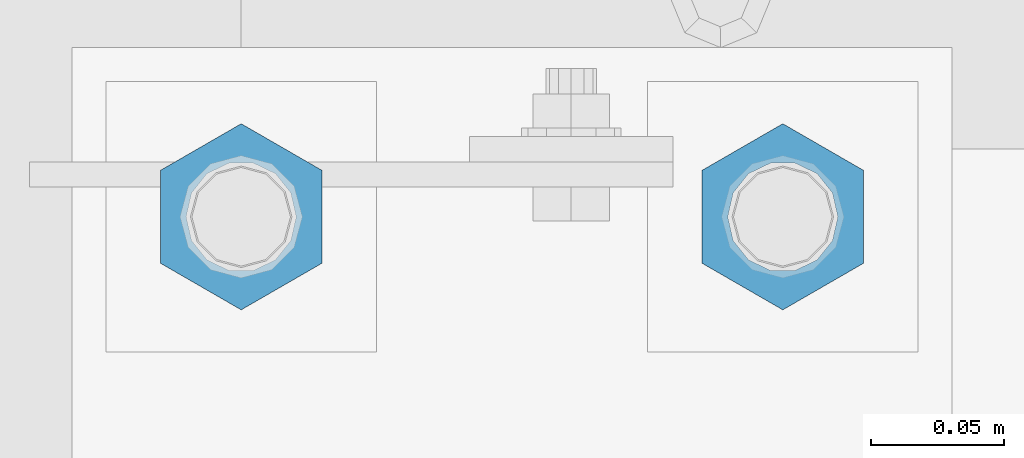
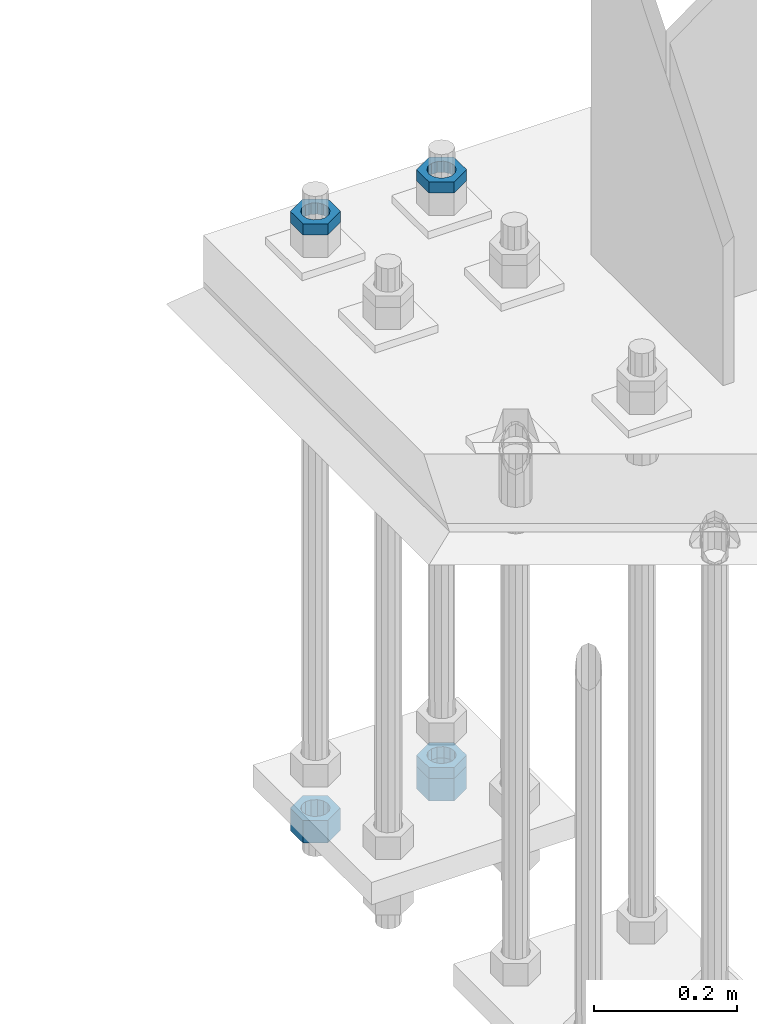
# One storey, part 2932 of 3843: 5 beams, 1 element without a shape of its own.
"""IFC2X3 building model written with IfcOpenShell, lengths in millimetres."""

import ifcopenshell
import ifcopenshell.guid

model = None  # the IFC model being written
_history = None  # IfcOwnerHistory: only IFC2X3 demands one
_inside = {}  # id of a spatial element -> (the spatial element, [elements in it])
_under = {}  # id of a project, library or spatial element -> (it, [spatial elements below it])
_declared = {}  # id of a project -> (the project, [libraries it declares])
_typed = {}  # id of a type object -> (the type object, [elements of that type])
_made_of = {}  # id of a material, layer set ... -> (it, [elements and type objects made of it])


def new_model(schema):
    """Start an empty IFC model of exactly this schema.

    Asked for "IFC4X3", IfcOpenShell would pick the latest addendum, in which some entities
    have other attributes; the version numbers below select the first issue.
    IFC2X3 requires an IfcOwnerHistory on every rooted entity: one is made here for all.
    """
    global model, _history
    if schema == "IFC4X3":
        model = ifcopenshell.file(schema_version=(4, 3, 0, 0))
    else:
        model = ifcopenshell.file(schema=schema)
    _inside.clear()
    _under.clear()
    _declared.clear()
    _typed.clear()
    _made_of.clear()
    _history = None
    if model.schema == "IFC2X3":
        org = make("IfcOrganization", Name="unknown")
        user = make(
            "IfcPersonAndOrganization",
            ThePerson=make("IfcPerson", FamilyName="unknown"),
            TheOrganization=org,
        )
        app = make(
            "IfcApplication",
            ApplicationDeveloper=org,
            Version="unknown",
            ApplicationFullName="unknown",
            ApplicationIdentifier="unknown",
        )
        _history = make(
            "IfcOwnerHistory",
            OwningUser=user,
            OwningApplication=app,
            ChangeAction="ADDED",
            CreationDate=0,
        )
    return model


def make(cls, **values):
    """One entity of the class cls with the attributes given. An attribute that is None is left unset."""
    return model.create_entity(
        cls, **{name: value for name, value in values.items() if value is not None}
    )


def rooted(cls, **values):
    """An entity with a GlobalId (a new one), such as an element, a storey or a relation."""
    return make(cls, GlobalId=ifcopenshell.guid.new(), OwnerHistory=_history, **values)


def si_unit(unit_type, name, prefix=None):
    """IfcSIUnit, for example si_unit("LENGTHUNIT", "METRE", prefix="MILLI")."""
    return make("IfcSIUnit", UnitType=unit_type, Prefix=prefix, Name=name)


def assignment(units):
    """IfcUnitAssignment: the units of a project."""
    return None if units is None else make("IfcUnitAssignment", Units=units)


def point(xyz):
    """IfcCartesianPoint."""
    return None if xyz is None else make("IfcCartesianPoint", Coordinates=xyz)


def direction(xyz):
    """IfcDirection."""
    return None if xyz is None else make("IfcDirection", DirectionRatios=xyz)


def frame(location, z_axis=None, x_axis=None):
    """IfcAxis2Placement3D, a coordinate frame: its origin and axes. An axis left out is left unset."""
    return make(
        "IfcAxis2Placement3D",
        Location=point(location),
        Axis=direction(z_axis),
        RefDirection=direction(x_axis),
    )


def origin_with_axes():
    """The frame at (0, 0, 0) with the z axis (0, 0, 1) and the x axis (1, 0, 0) written out."""
    return frame((0.0, 0.0, 0.0), z_axis=(0.0, 0.0, 1.0), x_axis=(1.0, 0.0, 0.0))


def place(relative_to, where):
    """IfcLocalPlacement: puts the frame where relative to a parent placement (None: the world)."""
    return make(
        "IfcLocalPlacement", PlacementRelTo=relative_to, RelativePlacement=where
    )


def context(
    kind, dimensions, precision=None, world=None, true_north=None, identifier=None
):
    """IfcGeometricRepresentationContext, for example the 3D "Model" context."""
    return make(
        "IfcGeometricRepresentationContext",
        ContextIdentifier=identifier,
        ContextType=kind,
        CoordinateSpaceDimension=dimensions,
        Precision=precision,
        WorldCoordinateSystem=world,
        TrueNorth=true_north,
    )


def subcontext(parent, identifier, kind, view, scale=None):
    """IfcGeometricRepresentationSubContext, for example "Body" below "Model"."""
    return make(
        "IfcGeometricRepresentationSubContext",
        ContextIdentifier=identifier,
        ContextType=kind,
        ParentContext=parent,
        TargetScale=scale,
        TargetView=view,
    )


def project(units=None, contexts=None):
    """IfcProject with its units and contexts."""
    return rooted(
        "IfcProject",
        Name="project",
        RepresentationContexts=contexts,
        UnitsInContext=assignment(units),
    )


def spatial(cls, under=None, at=None, **own):
    """A site, building, storey or space (cls), placed at a placement, below another one or the project."""
    s = rooted(cls, ObjectPlacement=at, **own)
    if under is not None:
        _under.setdefault(under.id(), (under, []))[1].append(s)
    return s


def faces_of(points, faces, orient=None, outer=None):
    """IfcFace entities. A face is a list of loops; a loop is a list of indices into points, from 0.

    orient and outer hold one flag for each loop. By default every Orientation is true, the
    first loop of a face is its IfcFaceOuterBound and the others are IfcFaceBound.
    """
    made = []
    for i, loops in enumerate(faces):
        bounds = []
        for j, loop in enumerate(loops):
            is_outer = j == 0 if outer is None else outer[i][j]
            bounds.append(
                make(
                    "IfcFaceOuterBound" if is_outer else "IfcFaceBound",
                    Bound=make("IfcPolyLoop", Polygon=[points[k] for k in loop]),
                    Orientation=True if orient is None else orient[i][j],
                )
            )
        made.append(make("IfcFace", Bounds=bounds))
    return made


def faceted_brep(points, faces, orient=None, outer=None, voids=None):
    """IfcFacetedBrep: a solid bounded by flat faces; with voids (closed shells), ...WithVoids."""
    shared = [point(p) for p in points]
    hull = make("IfcClosedShell", CfsFaces=faces_of(shared, faces, orient, outer))
    if voids is None:
        return make("IfcFacetedBrep", Outer=hull)
    return make(
        "IfcFacetedBrepWithVoids",
        Outer=hull,
        Voids=[
            make(cls, CfsFaces=faces_of(shared, fs, o, b)) for cls, fs, o, b in voids
        ],
    )


def shape(context_of_items, identifier, shape_type, items):
    """IfcShapeRepresentation: the items that make up one representation, for example the "Body"."""
    return make(
        "IfcShapeRepresentation",
        ContextOfItems=context_of_items,
        RepresentationIdentifier=identifier,
        RepresentationType=shape_type,
        Items=items,
    )


def material(Name=None, Category=None):
    """IfcMaterial."""
    return make("IfcMaterial", Name=Name, Category=Category)


def made_of(thing, what):
    """Note that an element or type object is made of a material, layer set ...; save() writes the relation."""
    if what is not None:
        _made_of.setdefault(what.id(), (what, []))[1].append(thing)
    return thing


def type_object(cls, material=None, **own):
    """A type object (cls), such as IfcWallType, which elements share."""
    return made_of(rooted(cls, **own), material)


def element(
    cls,
    number,
    at=None,
    inside=None,
    cuts=None,
    type_object=None,
    material=None,
    context=None,
    identifier="Body",
    shape_type=None,
    held_by="IfcProductDefinitionShape",
    body=None,
    shapes=None,
    **own,
):
    """One element of the class cls, such as IfcWall. Its Tag is "e" and its number.

    at: its placement. inside: the storey or other place that contains it. cuts: it is an
    opening in that element (IfcRelVoidsElement). A single representation is given by context,
    identifier, shape_type and body (its items); several are given by shapes. held_by: the class
    of the entity that holds the representations. save() writes the other relations.
    """
    e = rooted(cls, Tag="e%d" % number, ObjectPlacement=at, **own)
    if body is not None:
        shapes = [shape(context, identifier, shape_type, body)]
    if shapes is not None:
        e.Representation = make(held_by, Representations=shapes)
    if inside is not None:
        _inside.setdefault(inside.id(), (inside, []))[1].append(e)
    if cuts is not None:
        rooted(
            "IfcRelVoidsElement", RelatingBuildingElement=cuts, RelatedOpeningElement=e
        )
    if type_object is not None:
        _typed.setdefault(type_object.id(), (type_object, []))[1].append(e)
    return made_of(e, material)


def aggregate(whole, parts):
    """IfcRelAggregates: a whole, such as a stair, and the parts it consists of."""
    return rooted("IfcRelAggregates", RelatingObject=whole, RelatedObjects=parts)


def save(model, path):
    """Write the relations noted so far, then the file.

    IfcRelAggregates (storeys below a building ...), IfcRelContainedInSpatialStructure (elements
    in a storey), IfcRelDefinesByType, IfcRelAssociatesMaterial and IfcRelDeclares: one each for
    every whole, place, type object, material and project.
    """
    for whole, parts in _under.values():
        aggregate(whole, parts)
    for where, things in _inside.values():
        rooted(
            "IfcRelContainedInSpatialStructure",
            RelatedElements=things,
            RelatingStructure=where,
        )
    for kind, things in _typed.values():
        rooted("IfcRelDefinesByType", RelatedObjects=things, RelatingType=kind)
    for what, things in _made_of.values():
        rooted("IfcRelAssociatesMaterial", RelatedObjects=things, RelatingMaterial=what)
    for by, libraries in _declared.values():
        rooted("IfcRelDeclares", RelatingContext=by, RelatedDefinitions=libraries)
    model.write(path)


model = new_model("IFC2X3")

# Units and contexts
model_context = context("Model", 3, precision=1e-05, world=origin_with_axes())
body_context = subcontext(model_context, "Body", "Model", "MODEL_VIEW")
ifc_project = project(units=[si_unit("LENGTHUNIT", "METRE", prefix="MILLI"), si_unit("AREAUNIT", "SQUARE_METRE"), si_unit("VOLUMEUNIT", "CUBIC_METRE"), si_unit("MASSUNIT", "GRAM", prefix="KILO"), si_unit("TIMEUNIT", "SECOND"), si_unit("PLANEANGLEUNIT", "RADIAN"), si_unit("SOLIDANGLEUNIT", "STERADIAN"), si_unit("THERMODYNAMICTEMPERATUREUNIT", "DEGREE_CELSIUS"), si_unit("LUMINOUSINTENSITYUNIT", "LUMEN")], contexts=[model_context])

# Site, building, storey
site_placement = place(None, origin_with_axes())
site = spatial("IfcSite", under=ifc_project, at=site_placement, CompositionType="ELEMENT")
building_placement = place(site_placement, origin_with_axes())
building = spatial("IfcBuilding", under=site, at=building_placement, Name="Undefined", CompositionType="ELEMENT")
storey_placement = place(building_placement, origin_with_axes())
storey = spatial("IfcBuildingStorey", under=building, at=storey_placement, Name="Undefined", CompositionType="ELEMENT", Elevation=0.0)

# Assembly, beams
assembly_placement = place(storey_placement, origin_with_axes())
assembly = element("IfcElementAssembly", 1, at=assembly_placement, inside=storey, Name="TEMPLATE", AssemblyPlace="NOTDEFINED", PredefinedType="RIGID_FRAME")
ifc_material = material(Name="STEEL/A572-50")
beam_type_1 = type_object("IfcBeamType", Name="1-1/2_HEAVY_HEX_NUT", PredefinedType="NOTDEFINED")
beam_1_placement = place(assembly_placement, frame((76504.8, 104940.1, 28746.4500015259), z_axis=(-1.0, 0.0, 0.0), x_axis=(0.0, 0.0, -1.0)))
beam_1 = element("IfcBeam", 2, at=beam_1_placement, type_object=beam_type_1, material=ifc_material, Name="NUT", ObjectType="1-1/2_HEAVY_HEX_NUT", context=body_context, shape_type="Brep", body=[
    faceted_brep([(0.0, -34.9199981689453, 0.0), (0.0, -17.4599990844727, -30.25), (38.0999999999985, -17.4599990844727, -30.25), (38.0999999999985, -34.9199981689453, 0.0), (0.0, 17.4599990844727, -30.25), (38.0999999999985, 17.4599990844727, -30.25), (0.0, 34.9199981689453, 0.0), (38.0999999999985, 34.9199981689453, 0.0), (0.0, 17.4599990844727, 30.25), (38.0999999999985, 17.4599990844727, 30.25), (0.0, -17.4599990844727, 30.25), (38.0999999999985, -17.4599990844727, 30.25), (0.0, 0.0, 20.6399993896484), (0.0, 8.9553601105581, 18.5959968835959), (38.0999999999985, 8.9553601105581, 18.5959968835959), (38.0999999999985, 0.0, 20.6399993896484), (0.0, 16.1370013209525, 12.8688291298167), (38.0999999999985, 16.1370013209525, 12.8688291298167), (0.0, 20.1225115123816, 4.59283194104501), (38.0999999999985, 20.1225115123816, 4.59283194104501), (0.0, 20.1225115123816, -4.59283194104501), (38.0999999999985, 20.1225115123816, -4.59283194104501), (0.0, 16.1370013209525, -12.8688291298167), (38.0999999999985, 16.1370013209525, -12.8688291298167), (0.0, 8.9553601105581, -18.5959968835959), (38.0999999999985, 8.9553601105581, -18.5959968835959), (0.0, 0.0, -20.6399993896484), (38.0999999999985, 0.0, -20.6399993896484), (0.0, -8.9553601105581, -18.5959968835959), (38.0999999999985, -8.9553601105581, -18.5959968835959), (0.0, -16.1370013209525, -12.8688291298167), (38.0999999999985, -16.1370013209525, -12.8688291298167), (0.0, -20.1225115123816, -4.59283194104501), (38.0999999999985, -20.1225115123816, -4.59283194104501), (0.0, -20.1225115123816, 4.59283194104501), (38.0999999999985, -20.1225115123816, 4.59283194104501), (0.0, -16.1370013209525, 12.8688291298167), (38.0999999999985, -16.1370013209525, 12.8688291298167), (0.0, -8.9553601105581, 18.5959968835959), (38.0999999999985, -8.9553601105581, 18.5959968835959)], [[[0, 1, 2, 3]], [[1, 4, 5, 2]], [[4, 6, 7, 5]], [[6, 8, 9, 7]], [[8, 10, 11, 9]], [[10, 0, 3, 11]], [[12, 13, 14, 15]], [[13, 16, 17, 14]], [[16, 18, 19, 17]], [[18, 20, 21, 19]], [[20, 22, 23, 21]], [[22, 24, 25, 23]], [[24, 26, 27, 25]], [[26, 28, 29, 27]], [[28, 30, 31, 29]], [[30, 32, 33, 31]], [[32, 34, 35, 33]], [[34, 36, 37, 35]], [[36, 38, 39, 37]], [[38, 12, 15, 39]], [[5, 7, 9, 11, 3, 2], [17, 19, 21, 23, 25, 27, 29, 31, 33, 35, 37, 39, 15, 14]], [[10, 8, 6, 4, 1, 0], [38, 36, 34, 32, 30, 28, 26, 24, 22, 20, 18, 16, 13, 12]]]),
])
beam_2_placement = place(assembly_placement, frame((76708.0, 104940.1, 28746.4500015259), z_axis=(-1.0, 0.0, 0.0), x_axis=(0.0, 0.0, -1.0)))
beam_2 = element("IfcBeam", 3, at=beam_2_placement, type_object=beam_type_1, material=ifc_material, Name="NUT", ObjectType="1-1/2_HEAVY_HEX_NUT", context=body_context, shape_type="Brep", body=[
    faceted_brep([(0.0, -34.9199981689453, 0.0), (0.0, -17.4599990844727, -30.25), (38.0999999999985, -17.4599990844727, -30.25), (38.0999999999985, -34.9199981689453, 0.0), (0.0, 17.4599990844727, -30.25), (38.0999999999985, 17.4599990844727, -30.25), (0.0, 34.9199981689453, 0.0), (38.0999999999985, 34.9199981689453, 0.0), (0.0, 17.4599990844727, 30.25), (38.0999999999985, 17.4599990844727, 30.25), (0.0, -17.4599990844727, 30.25), (38.0999999999985, -17.4599990844727, 30.25), (0.0, 0.0, 20.6399993896484), (0.0, 8.9553601105581, 18.5959968835959), (38.0999999999985, 8.9553601105581, 18.5959968835959), (38.0999999999985, 0.0, 20.6399993896484), (0.0, 16.1370013209525, 12.8688291298167), (38.0999999999985, 16.1370013209525, 12.8688291298167), (0.0, 20.1225115123816, 4.59283194104501), (38.0999999999985, 20.1225115123816, 4.59283194104501), (0.0, 20.1225115123816, -4.59283194104501), (38.0999999999985, 20.1225115123816, -4.59283194104501), (0.0, 16.1370013209525, -12.8688291298167), (38.0999999999985, 16.1370013209525, -12.8688291298167), (0.0, 8.9553601105581, -18.5959968835959), (38.0999999999985, 8.9553601105581, -18.5959968835959), (0.0, 0.0, -20.6399993896484), (38.0999999999985, 0.0, -20.6399993896484), (0.0, -8.9553601105581, -18.5959968835959), (38.0999999999985, -8.9553601105581, -18.5959968835959), (0.0, -16.1370013209525, -12.8688291298167), (38.0999999999985, -16.1370013209525, -12.8688291298167), (0.0, -20.1225115123816, -4.59283194104501), (38.0999999999985, -20.1225115123816, -4.59283194104501), (0.0, -20.1225115123816, 4.59283194104501), (38.0999999999985, -20.1225115123816, 4.59283194104501), (0.0, -16.1370013209525, 12.8688291298167), (38.0999999999985, -16.1370013209525, 12.8688291298167), (0.0, -8.9553601105581, 18.5959968835959), (38.0999999999985, -8.9553601105581, 18.5959968835959)], [[[0, 1, 2, 3]], [[1, 4, 5, 2]], [[4, 6, 7, 5]], [[6, 8, 9, 7]], [[8, 10, 11, 9]], [[10, 0, 3, 11]], [[12, 13, 14, 15]], [[13, 16, 17, 14]], [[16, 18, 19, 17]], [[18, 20, 21, 19]], [[20, 22, 23, 21]], [[22, 24, 25, 23]], [[24, 26, 27, 25]], [[26, 28, 29, 27]], [[28, 30, 31, 29]], [[30, 32, 33, 31]], [[32, 34, 35, 33]], [[34, 36, 37, 35]], [[36, 38, 39, 37]], [[38, 12, 15, 39]], [[5, 7, 9, 11, 3, 2], [17, 19, 21, 23, 25, 27, 29, 31, 33, 35, 37, 39, 15, 14]], [[10, 8, 6, 4, 1, 0], [38, 36, 34, 32, 30, 28, 26, 24, 22, 20, 18, 16, 13, 12]]]),
])
beam_type_2 = type_object("IfcBeamType", Name="1-1/2_HALF_NUT", PredefinedType="NOTDEFINED")
beam_3_placement = place(assembly_placement, frame((76504.8, 104940.1, 29762.45), z_axis=(-1.0, 0.0, 0.0), x_axis=(0.0, 0.0, -1.0)))
beam_3 = element("IfcBeam", 4, at=beam_3_placement, type_object=beam_type_2, material=ifc_material, Name="NUT", ObjectType="1-1/2_HALF_NUT", context=body_context, shape_type="Brep", body=[
    faceted_brep([(0.0, -34.9199981689453, 0.0), (0.0, -17.4599990844727, -30.25), (19.0500000000029, -17.4599990844727, -30.25), (19.0500000000029, -34.9199981689453, 0.0), (0.0, 17.4599990844727, -30.25), (19.0500000000029, 17.4599990844727, -30.25), (0.0, 34.9199981689453, 0.0), (19.0500000000029, 34.9199981689453, 0.0), (0.0, 17.4599990844727, 30.25), (19.0500000000029, 17.4599990844727, 30.25), (0.0, -17.4599990844727, 30.25), (19.0500000000029, -17.4599990844727, 30.25), (0.0, 0.0, 20.6399993896484), (0.0, 8.9553601105581, 18.5959968835959), (19.0500000000029, 8.95536011056538, 18.5959968835959), (19.0500000000029, 0.0, 20.6399993896484), (0.0, 16.1370013209525, 12.8688291298167), (19.0500000000029, 16.1370013209489, 12.8688291298167), (0.0, 20.1225115123816, 4.59283194104501), (19.0500000000029, 20.1225115123852, 4.59283194104501), (0.0, 20.1225115123816, -4.59283194104501), (19.0500000000029, 20.1225115123852, -4.59283194104501), (0.0, 16.1370013209525, -12.8688291298167), (19.0500000000029, 16.1370013209489, -12.8688291298167), (0.0, 8.9553601105581, -18.5959968835959), (19.0500000000029, 8.95536011056538, -18.5959968835959), (0.0, 0.0, -20.6399993896484), (19.0500000000029, 0.0, -20.6399993896484), (0.0, -8.9553601105581, -18.5959968835959), (19.0500000000029, -8.95536011056538, -18.5959968835959), (0.0, -16.1370013209525, -12.8688291298167), (19.0500000000029, -16.1370013209489, -12.8688291298167), (0.0, -20.1225115123816, -4.59283194104501), (19.0500000000029, -20.1225115123852, -4.59283194104501), (0.0, -20.1225115123816, 4.59283194104501), (19.0500000000029, -20.1225115123852, 4.59283194104501), (0.0, -16.1370013209525, 12.8688291298167), (19.0500000000029, -16.1370013209489, 12.8688291298167), (0.0, -8.9553601105581, 18.5959968835959), (19.0500000000029, -8.95536011056538, 18.5959968835959)], [[[0, 1, 2, 3]], [[1, 4, 5, 2]], [[4, 6, 7, 5]], [[6, 8, 9, 7]], [[8, 10, 11, 9]], [[10, 0, 3, 11]], [[12, 13, 14, 15]], [[13, 16, 17, 14]], [[16, 18, 19, 17]], [[18, 20, 21, 19]], [[20, 22, 23, 21]], [[22, 24, 25, 23]], [[24, 26, 27, 25]], [[26, 28, 29, 27]], [[28, 30, 31, 29]], [[30, 32, 33, 31]], [[32, 34, 35, 33]], [[34, 36, 37, 35]], [[36, 38, 39, 37]], [[38, 12, 15, 39]], [[5, 7, 9, 11, 3, 2], [17, 19, 21, 23, 25, 27, 29, 31, 33, 35, 37, 39, 15, 14]], [[10, 8, 6, 4, 1, 0], [38, 36, 34, 32, 30, 28, 26, 24, 22, 20, 18, 16, 13, 12]]]),
])
beam_4_placement = place(assembly_placement, frame((76708.0, 104940.1, 28765.5), z_axis=(-1.0, 0.0, 0.0), x_axis=(0.0, 0.0, -1.0)))
beam_4 = element("IfcBeam", 5, at=beam_4_placement, type_object=beam_type_2, material=ifc_material, Name="NUT", ObjectType="1-1/2_HALF_NUT", context=body_context, shape_type="Brep", body=[
    faceted_brep([(0.0, -34.9199981689453, 0.0), (0.0, -17.4599990844727, -30.25), (19.0500000000029, -17.4599990844727, -30.25), (19.0500000000029, -34.9199981689453, 0.0), (0.0, 17.4599990844727, -30.25), (19.0500000000029, 17.4599990844727, -30.25), (0.0, 34.9199981689453, 0.0), (19.0500000000029, 34.9199981689453, 0.0), (0.0, 17.4599990844727, 30.25), (19.0500000000029, 17.4599990844727, 30.25), (0.0, -17.4599990844727, 30.25), (19.0500000000029, -17.4599990844727, 30.25), (0.0, 0.0, 20.6399993896484), (0.0, 8.9553601105581, 18.5959968835959), (19.0500000000029, 8.95536011056538, 18.5959968835959), (19.0500000000029, 0.0, 20.6399993896484), (0.0, 16.1370013209525, 12.8688291298167), (19.0500000000029, 16.1370013209489, 12.8688291298167), (0.0, 20.1225115123816, 4.59283194104501), (19.0500000000029, 20.1225115123852, 4.59283194104501), (0.0, 20.1225115123816, -4.59283194104501), (19.0500000000029, 20.1225115123852, -4.59283194104501), (0.0, 16.1370013209525, -12.8688291298167), (19.0500000000029, 16.1370013209489, -12.8688291298167), (0.0, 8.9553601105581, -18.5959968835959), (19.0500000000029, 8.95536011056538, -18.5959968835959), (0.0, 0.0, -20.6399993896484), (19.0500000000029, 0.0, -20.6399993896484), (0.0, -8.9553601105581, -18.5959968835959), (19.0500000000029, -8.95536011056538, -18.5959968835959), (0.0, -16.1370013209525, -12.8688291298167), (19.0500000000029, -16.1370013209489, -12.8688291298167), (0.0, -20.1225115123816, -4.59283194104501), (19.0500000000029, -20.1225115123852, -4.59283194104501), (0.0, -20.1225115123816, 4.59283194104501), (19.0500000000029, -20.1225115123852, 4.59283194104501), (0.0, -16.1370013209525, 12.8688291298167), (19.0500000000029, -16.1370013209489, 12.8688291298167), (0.0, -8.9553601105581, 18.5959968835959), (19.0500000000029, -8.95536011056538, 18.5959968835959)], [[[0, 1, 2, 3]], [[1, 4, 5, 2]], [[4, 6, 7, 5]], [[6, 8, 9, 7]], [[8, 10, 11, 9]], [[10, 0, 3, 11]], [[12, 13, 14, 15]], [[13, 16, 17, 14]], [[16, 18, 19, 17]], [[18, 20, 21, 19]], [[20, 22, 23, 21]], [[22, 24, 25, 23]], [[24, 26, 27, 25]], [[26, 28, 29, 27]], [[28, 30, 31, 29]], [[30, 32, 33, 31]], [[32, 34, 35, 33]], [[34, 36, 37, 35]], [[36, 38, 39, 37]], [[38, 12, 15, 39]], [[5, 7, 9, 11, 3, 2], [17, 19, 21, 23, 25, 27, 29, 31, 33, 35, 37, 39, 15, 14]], [[10, 8, 6, 4, 1, 0], [38, 36, 34, 32, 30, 28, 26, 24, 22, 20, 18, 16, 13, 12]]]),
])
beam_5_placement = place(assembly_placement, frame((76708.0, 104940.1, 29762.45), z_axis=(-1.0, 0.0, 0.0), x_axis=(0.0, 0.0, -1.0)))
beam_5 = element("IfcBeam", 6, at=beam_5_placement, type_object=beam_type_2, material=ifc_material, Name="NUT", ObjectType="1-1/2_HALF_NUT", context=body_context, shape_type="Brep", body=[
    faceted_brep([(0.0, -34.9199981689453, 0.0), (0.0, -17.4599990844727, -30.25), (19.0500000000029, -17.4599990844727, -30.25), (19.0500000000029, -34.9199981689453, 0.0), (0.0, 17.4599990844727, -30.25), (19.0500000000029, 17.4599990844727, -30.25), (0.0, 34.9199981689453, 0.0), (19.0500000000029, 34.9199981689453, 0.0), (0.0, 17.4599990844727, 30.25), (19.0500000000029, 17.4599990844727, 30.25), (0.0, -17.4599990844727, 30.25), (19.0500000000029, -17.4599990844727, 30.25), (0.0, 0.0, 20.6399993896484), (0.0, 8.9553601105581, 18.5959968835959), (19.0500000000029, 8.95536011056538, 18.5959968835959), (19.0500000000029, 0.0, 20.6399993896484), (0.0, 16.1370013209525, 12.8688291298167), (19.0500000000029, 16.1370013209489, 12.8688291298167), (0.0, 20.1225115123816, 4.59283194104501), (19.0500000000029, 20.1225115123852, 4.59283194104501), (0.0, 20.1225115123816, -4.59283194104501), (19.0500000000029, 20.1225115123852, -4.59283194104501), (0.0, 16.1370013209525, -12.8688291298167), (19.0500000000029, 16.1370013209489, -12.8688291298167), (0.0, 8.9553601105581, -18.5959968835959), (19.0500000000029, 8.95536011056538, -18.5959968835959), (0.0, 0.0, -20.6399993896484), (19.0500000000029, 0.0, -20.6399993896484), (0.0, -8.9553601105581, -18.5959968835959), (19.0500000000029, -8.95536011056538, -18.5959968835959), (0.0, -16.1370013209525, -12.8688291298167), (19.0500000000029, -16.1370013209489, -12.8688291298167), (0.0, -20.1225115123816, -4.59283194104501), (19.0500000000029, -20.1225115123852, -4.59283194104501), (0.0, -20.1225115123816, 4.59283194104501), (19.0500000000029, -20.1225115123852, 4.59283194104501), (0.0, -16.1370013209525, 12.8688291298167), (19.0500000000029, -16.1370013209489, 12.8688291298167), (0.0, -8.9553601105581, 18.5959968835959), (19.0500000000029, -8.95536011056538, 18.5959968835959)], [[[0, 1, 2, 3]], [[1, 4, 5, 2]], [[4, 6, 7, 5]], [[6, 8, 9, 7]], [[8, 10, 11, 9]], [[10, 0, 3, 11]], [[12, 13, 14, 15]], [[13, 16, 17, 14]], [[16, 18, 19, 17]], [[18, 20, 21, 19]], [[20, 22, 23, 21]], [[22, 24, 25, 23]], [[24, 26, 27, 25]], [[26, 28, 29, 27]], [[28, 30, 31, 29]], [[30, 32, 33, 31]], [[32, 34, 35, 33]], [[34, 36, 37, 35]], [[36, 38, 39, 37]], [[38, 12, 15, 39]], [[5, 7, 9, 11, 3, 2], [17, 19, 21, 23, 25, 27, 29, 31, 33, 35, 37, 39, 15, 14]], [[10, 8, 6, 4, 1, 0], [38, 36, 34, 32, 30, 28, 26, 24, 22, 20, 18, 16, 13, 12]]]),
])
aggregate(assembly, [beam_1, beam_3, beam_4, beam_2, beam_5])

save(model, "model.ifc")
